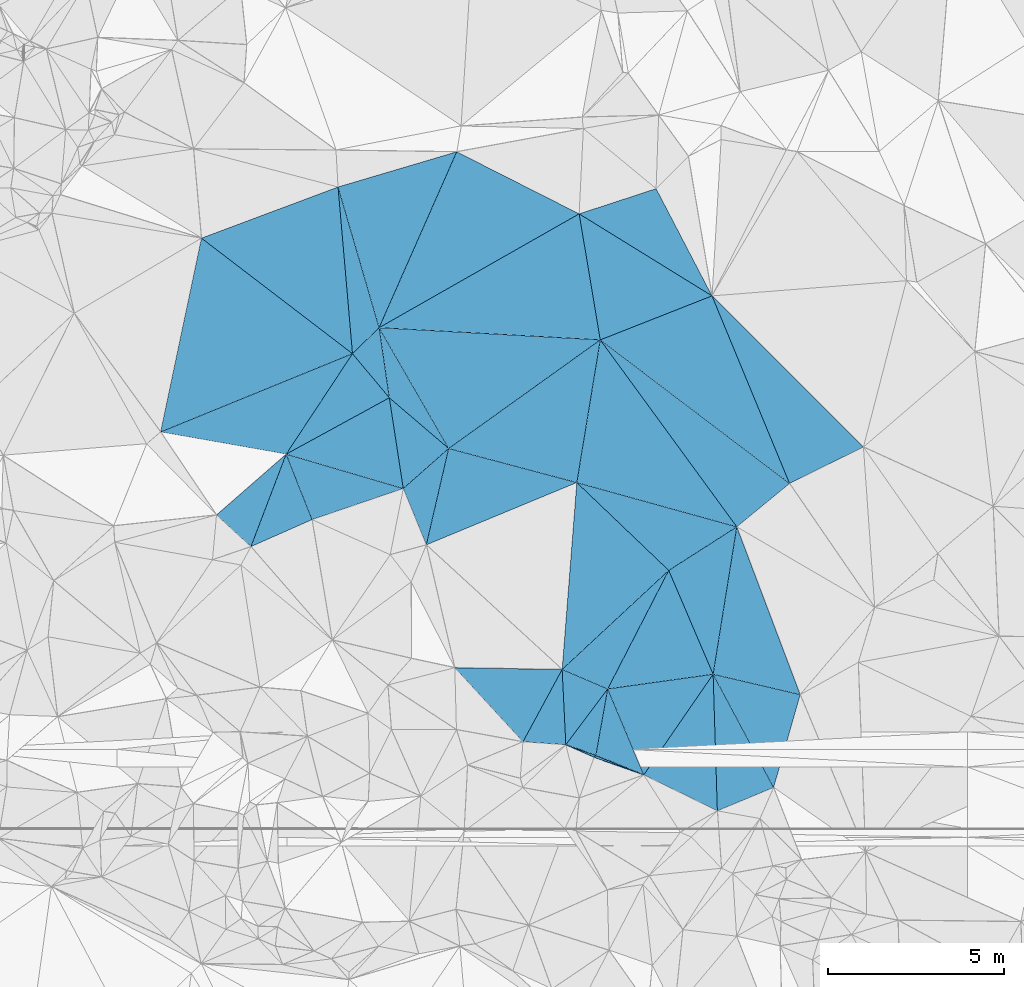
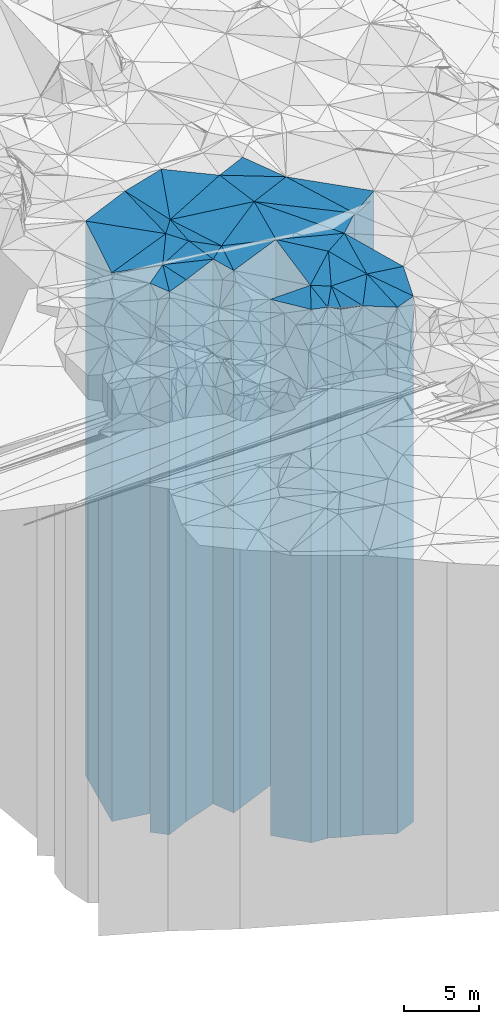
# One storey, part 218 of 275: 42 plates.
"""IFC2X3 building model written with IfcOpenShell, lengths in millimetres."""

from ifc_helpers import new_model, si_unit, frame, origin_with_axes, place, context, subcontext, project, spatial, faceted_brep, material, type_object, element, save


model = new_model("IFC2X3")

# Units and contexts
model_context = context("Model", 3, precision=1e-05, world=origin_with_axes())
body_context = subcontext(model_context, "Body", "Model", "MODEL_VIEW")
ifc_project = project(units=[si_unit("LENGTHUNIT", "METRE", prefix="MILLI"), si_unit("AREAUNIT", "SQUARE_METRE"), si_unit("VOLUMEUNIT", "CUBIC_METRE"), si_unit("MASSUNIT", "GRAM", prefix="KILO"), si_unit("TIMEUNIT", "SECOND"), si_unit("PLANEANGLEUNIT", "RADIAN"), si_unit("SOLIDANGLEUNIT", "STERADIAN"), si_unit("THERMODYNAMICTEMPERATUREUNIT", "DEGREE_CELSIUS"), si_unit("LUMINOUSINTENSITYUNIT", "LUMEN")], contexts=[model_context])

# Site, building, storey
site_placement = place(None, origin_with_axes())
site = spatial("IfcSite", under=ifc_project, at=site_placement, CompositionType="ELEMENT")
building_placement = place(site_placement, origin_with_axes())
building = spatial("IfcBuilding", under=site, at=building_placement, Name="Undefined", CompositionType="ELEMENT")
storey_placement = place(building_placement, origin_with_axes())
storey = spatial("IfcBuildingStorey", under=building, at=storey_placement, Name="Undefined", CompositionType="ELEMENT", Elevation=0.0)

# Plates
ifc_material = material()
plate_type_1 = type_object("IfcPlateType", PredefinedType="NOTDEFINED")
plate_1_placement = place(storey_placement, frame((-117335.519000868, 70928.3813490545, 29289.0), z_axis=(0.823524652008645, -0.567280484005963, 0.0), x_axis=(-0.567280484005959, -0.823524652008648, 0.0)))
element("IfcPlate", 1, at=plate_1_placement, inside=storey, type_object=plate_type_1, material=ifc_material, Name="00", context=body_context, shape_type="Brep", body=[
    faceted_brep([(-1.2732925824821e-11, -21871.0, 0.0), (3129.30419921872, -21461.0, 2301.9677734375), (3129.30419921872, 21461.0, 2301.9677734375), (-1.2732925824821e-11, 21461.0, 0.0), (3474.76611328123, -21701.0, 4.07453626394272e-09), (3474.76611328123, 21461.0, 4.07453626394272e-09)], [[[0, 1, 2, 3]], [[1, 4, 5, 2]], [[4, 0, 3, 5]], [[5, 3, 2]], [[4, 1, 0]]]),
])
plate_type_2 = type_object("IfcPlateType", PredefinedType="NOTDEFINED")
plate_2_placement = place(storey_placement, frame((-117214.984869905, 67045.4608601347, 29264.0), z_axis=(-0.383147422917195, 0.923687204800365, 0.0), x_axis=(0.923687204800366, 0.383147422917194, 0.0)))
element("IfcPlate", 2, at=plate_2_placement, inside=storey, type_object=plate_type_2, material=ifc_material, Name="00", context=body_context, shape_type="Brep", body=[
    faceted_brep([(-1.45519152283669e-11, -21486.0, 0.0), (1376.39514160156, -21896.0, 3632.78637695313), (1376.39514160156, 21436.0, 3632.78637695313), (-1.45519152283669e-11, 21436.0, 0.0), (1730.46240234374, -21436.0, 7.5960997492075e-09), (1730.46240234374, 21436.0, 7.5960997492075e-09)], [[[0, 1, 2, 3]], [[1, 4, 5, 2]], [[4, 0, 3, 5]], [[5, 3, 2]], [[4, 1, 0]]]),
])
plate_type_3 = type_object("IfcPlateType", PredefinedType="NOTDEFINED")
plate_3_placement = place(storey_placement, frame((-119306.686039508, 68066.8257396384, 29409.0), z_axis=(-0.823524652008645, 0.567280484005963, 0.0), x_axis=(0.567280484005957, 0.82352465200865, 0.0)))
element("IfcPlate", 3, at=plate_3_placement, inside=storey, type_object=plate_type_3, material=ifc_material, Name="00", context=body_context, shape_type="Brep", body=[
    faceted_brep([(5.45696821063757e-12, -21581.0, 0.0), (1430.59985351561, -22061.0, 2231.22924804688), (1430.59985351561, 21581.0, 2231.22924804688), (5.45696821063757e-12, 21581.0, 0.0), (3474.76611328126, -21751.0, 4.07453626394272e-09), (3474.76611328126, 21581.0, 4.07453626394272e-09)], [[[0, 1, 2, 3]], [[1, 4, 5, 2]], [[4, 0, 3, 5]], [[5, 3, 2]], [[4, 1, 0]]]),
])
plate_type_4 = type_object("IfcPlateType", PredefinedType="NOTDEFINED")
plate_4_placement = place(storey_placement, frame((-121522.572678423, 68923.9409031251, 29359.0), z_axis=(0.405411489970543, 0.914134302933581, 0.0), x_axis=(0.914134302933581, -0.405411489970543, 0.0)))
element("IfcPlate", 4, at=plate_4_placement, inside=storey, type_object=plate_type_4, material=ifc_material, Name="00", context=body_context, shape_type="Brep", body=[
    faceted_brep([(0.0, -21771.0, 1.45519152283669e-11), (902.671997070313, -21551.0, 71.995040893562), (902.671997070313, 21531.0, 71.995040893562), (0.0, 21531.0, 0.0), (877.838256835908, -21531.0, -9.53150447458029e-10), (877.838256835908, 21531.0, -9.53150447458029e-10)], [[[0, 1, 2, 3]], [[1, 4, 5, 2]], [[4, 0, 3, 5]], [[5, 3, 2]], [[4, 1, 0]]]),
])
plate_5_placement = place(storey_placement, frame((-119306.686039508, 68066.8257396384, 29359.0), z_axis=(-0.378622870041879, -0.925551037102358, 0.0), x_axis=(-0.925551037102361, 0.378622870041871, 0.0)))
element("IfcPlate", 5, at=plate_5_placement, inside=storey, type_object=plate_type_4, material=ifc_material, Name="00", context=body_context, shape_type="Brep", body=[
    faceted_brep([(-1.45519152283669e-11, -21631.0, 0.0), (1497.97351074222, -21531.0, 71.2414321899596), (1497.97351074222, 21531.0, 71.2414321899596), (0.0, 21531.0, 0.0), (1471.05407714847, -21551.0, -7.35235516913235e-09), (1471.05407714847, 21531.0, -7.35235516913235e-09)], [[[0, 1, 2, 3]], [[1, 4, 5, 2]], [[4, 0, 3, 5]], [[5, 3, 2]], [[4, 1, 0]]]),
])
plate_type_5 = type_object("IfcPlateType", PredefinedType="NOTDEFINED")
plate_6_placement = place(storey_placement, frame((-120332.606968009, 70510.692808131, 29369.0), z_axis=(0.984547475358155, -0.175117871063699, 0.0), x_axis=(-0.175117871063703, -0.984547475358155, 0.0)))
element("IfcPlate", 6, at=plate_6_placement, inside=storey, type_object=plate_type_5, material=ifc_material, Name="00", context=body_context, shape_type="Brep", body=[
    faceted_brep([(0.0, -22101.0, -1.45519152283669e-11), (2226.4460449219, -21621.0, 1438.03271484374), (2226.4460449219, 21541.0, 1438.03271484374), (0.0, 21541.0, -1.45519152283669e-11), (1916.50720214844, -21541.0, 9.73523128777742e-09), (1916.50720214844, 21541.0, 9.73523128777742e-09)], [[[0, 1, 2, 3]], [[1, 4, 5, 2]], [[4, 0, 3, 5]], [[5, 3, 2]], [[4, 1, 0]]]),
])
plate_type_6 = type_object("IfcPlateType", PredefinedType="NOTDEFINED")
plate_7_placement = place(storey_placement, frame((-118597.047680639, 73880.3714218895, 29649.0), z_axis=(0.68073982928558, -0.732525279307301, 0.0), x_axis=(-0.732525279307302, -0.680739829285579, 0.0)))
element("IfcPlate", 7, at=plate_7_placement, inside=storey, type_object=plate_type_6, material=ifc_material, Name="00", context=body_context, shape_type="Brep", body=[
    faceted_brep([(0.0, -22011.0, 2.91038304567337e-11), (3565.21557617187, -21821.0, 1286.91040039063), (3565.21557617187, 21821.0, 1286.91040039063), (0.0, 21821.0, 2.91038304567337e-11), (4136.49609375, -22001.0, 1.07975210994482e-08), (4136.49609375, 21821.0, 1.07975210994482e-08)], [[[0, 1, 2, 3]], [[1, 4, 5, 2]], [[4, 0, 3, 5]], [[5, 3, 2]], [[4, 1, 0]]]),
])
plate_type_7 = type_object("IfcPlateType", PredefinedType="NOTDEFINED")
plate_8_placement = place(storey_placement, frame((-126539.90181084, 78787.4549005297, 30069.0), z_axis=(-0.767759475959688, -0.640738157966345, 0.0), x_axis=(-0.640738157966349, 0.767759475959685, 0.0)))
element("IfcPlate", 8, at=plate_8_placement, inside=storey, type_object=plate_type_7, material=ifc_material, Name="00", context=body_context, shape_type="Brep", body=[
    faceted_brep([(-2.91038304567337e-11, -22241.0, 3.63797880709171e-11), (648.352050781221, -22301.0, 3278.25244140628), (648.352050781221, 22241.0, 3278.25244140628), (-2.91038304567337e-11, 22241.0, 3.63797880709171e-11), (1633.21765136716, -22441.0, 1.4239049050957e-08), (1633.21765136716, 22241.0, 1.4239049050957e-08)], [[[0, 1, 2, 3]], [[1, 4, 5, 2]], [[4, 0, 3, 5]], [[5, 3, 2]], [[4, 1, 0]]]),
])
plate_type_8 = type_object("IfcPlateType", PredefinedType="NOTDEFINED")
plate_9_placement = place(storey_placement, frame((-127586.366699978, 80041.3732534547, 30169.0), z_axis=(-0.607388450675607, -0.794404978575717, 0.0), x_axis=(-0.79440497857572, 0.607388450675603, 0.0)))
element("IfcPlate", 9, at=plate_9_placement, inside=storey, type_object=plate_type_8, material=ifc_material, Name="00", context=body_context, shape_type="Brep", body=[
    faceted_brep([(2.91038304567337e-11, -22341.0, 1.45519152283669e-11), (2981.69409179685, -22401.0, 5082.37158203126), (2981.69409179685, 22341.0, 5082.37158203126), (0.0, 22341.0, 0.0), (5406.25585937503, -22881.0, -1.52067514136434e-09), (5406.25585937503, 22341.0, -1.52067514136434e-09)], [[[0, 1, 2, 3]], [[1, 4, 5, 2]], [[4, 0, 3, 5]], [[5, 3, 2]], [[4, 1, 0]]]),
])
plate_type_9 = type_object("IfcPlateType", PredefinedType="NOTDEFINED")
plate_10_placement = place(storey_placement, frame((-125488.863877859, 74605.2641751521, 29924.0), z_axis=(-0.38255954606827, 0.92393083816487, 0.0), x_axis=(0.923930838164871, 0.382559546068267, 0.0)))
element("IfcPlate", 10, at=plate_10_placement, inside=storey, type_object=plate_type_9, material=ifc_material, Name="00", context=body_context, shape_type="Brep", body=[
    faceted_brep([(0.0, -22136.0, 0.0), (1636.08264160156, -22266.0, 2289.50512695314), (1636.08264160156, 22096.0, 2289.50512695314), (0.0, 22096.0, 0.0), (4631.306640625, -22096.0, -1.55705492943525e-08), (4631.306640625, 22096.0, -1.55705492943525e-08)], [[[0, 1, 2, 3]], [[1, 4, 5, 2]], [[4, 0, 3, 5]], [[5, 3, 2]], [[4, 1, 0]]]),
])
plate_type_10 = type_object("IfcPlateType", PredefinedType="NOTDEFINED")
plate_11_placement = place(storey_placement, frame((-126830.555289719, 80780.1215949911, 30009.0), z_axis=(0.989528991714559, 0.144334245958363, 0.0), x_axis=(0.144334245958364, -0.989528991714558, 0.0)))
element("IfcPlate", 11, at=plate_11_placement, inside=storey, type_object=plate_type_10, material=ifc_material, Name="00", context=body_context, shape_type="Brep", body=[
    faceted_brep([(0.0, -22931.0, -1.45519152283669e-11), (3683.07397460938, -22181.0, 1461.1525878906), (3683.07397460938, 22181.0, 1461.1525878906), (0.0, 22181.0, -1.45519152283669e-11), (2013.75268554688, -22301.0, 8.73114913702011e-11), (2013.75268554688, 22181.0, 8.73114913702011e-11)], [[[0, 1, 2, 3]], [[1, 4, 5, 2]], [[4, 0, 3, 5]], [[5, 3, 2]], [[4, 1, 0]]]),
])
plate_type_11 = type_object("IfcPlateType", PredefinedType="NOTDEFINED")
plate_12_placement = place(storey_placement, frame((-120543.166441148, 80433.0748159088, 29764.0), z_axis=(0.807613661011617, 0.58971194200848, 0.0), x_axis=(0.589711942008481, -0.807613661011616, 0.0)))
element("IfcPlate", 12, at=plate_12_placement, inside=storey, type_object=plate_type_11, material=ifc_material, Name="00", context=body_context, shape_type="Brep", body=[
    faceted_brep([(0.0, -22656.0, 0.0), (6470.38330078124, -22296.0, 1937.81896972655), (6470.38330078124, 21936.0, 1937.81896972655), (0.0, 21936.0, 0.0), (6580.64599609374, -21936.0, -2.33703758567572e-08), (6580.64599609374, 21936.0, -2.33703758567572e-08)], [[[0, 1, 2, 3]], [[1, 4, 5, 2]], [[4, 0, 3, 5]], [[5, 3, 2]], [[4, 1, 0]]]),
])
plate_type_12 = type_object("IfcPlateType", PredefinedType="NOTDEFINED")
plate_13_placement = place(storey_placement, frame((-124853.10875097, 77346.5075825559, 29924.0), z_axis=(0.257157203942215, 0.966369583782841, 0.0), x_axis=(0.966369583782842, -0.257157203942214, 0.0)))
element("IfcPlate", 13, at=plate_13_placement, inside=storey, type_object=plate_type_12, material=ifc_material, Name="00", context=body_context, shape_type="Brep", body=[
    faceted_brep([(0.0, -22266.0, 0.0), (3371.26416015625, -22496.0, 4091.09741210938), (3371.26416015625, 22096.0, 4091.09741210938), (0.0, 22096.0, 0.0), (3770.0397949219, -22096.0, -7.69796315580606e-09), (3770.0397949219, 22096.0, -7.69796315580606e-09)], [[[0, 1, 2, 3]], [[1, 4, 5, 2]], [[4, 0, 3, 5]], [[5, 3, 2]], [[4, 1, 0]]]),
])
plate_type_13 = type_object("IfcPlateType", PredefinedType="NOTDEFINED")
plate_14_placement = place(storey_placement, frame((-115162.495216853, 76350.259956521, 29944.0), z_axis=(-0.924123928763436, -0.382092873902186, 0.0), x_axis=(-0.382092873902188, 0.924123928763435, 0.0)))
element("IfcPlate", 14, at=plate_14_placement, inside=storey, type_object=plate_type_13, material=ifc_material, Name="00", context=body_context, shape_type="Brep", body=[
    faceted_brep([(1.45519152283669e-11, -22116.0, 1.45519152283669e-11), (5828.94287109374, -22476.0, 3412.39257812503), (5828.94287109374, 22116.0, 3412.39257812503), (1.45519152283669e-11, 22116.0, 1.45519152283669e-11), (5771.69824218751, -22626.0, 1.97906047105789e-08), (5771.69824218751, 22116.0, 1.97906047105789e-08)], [[[0, 1, 2, 3]], [[1, 4, 5, 2]], [[4, 0, 3, 5]], [[5, 3, 2]], [[4, 1, 0]]]),
])
plate_type_14 = type_object("IfcPlateType", PredefinedType="NOTDEFINED")
plate_15_placement = place(storey_placement, frame((-131881.123092767, 83325.0704877612, 30169.0), z_axis=(0.607388450675607, 0.794404978575717, 0.0), x_axis=(0.79440497857572, -0.607388450675604, 0.0)))
element("IfcPlate", 15, at=plate_15_placement, inside=storey, type_object=plate_type_14, material=ifc_material, Name="00", context=body_context, shape_type="Brep", body=[
    faceted_brep([(0.0, -22881.0, 0.0), (2201.44970703122, -23081.0, 3514.37329101563), (2201.44970703122, 22341.0, 3514.37329101563), (0.0, 22341.0, 0.0), (5406.255859375, -22341.0, 4.6253262553364e-08), (5406.25585937503, 22341.0, -1.52067514136434e-09)], [[[0, 1, 2, 3]], [[1, 4, 5, 2]], [[4, 0, 3, 5]], [[5, 3, 2]], [[4, 1, 0]]]),
])
plate_type_15 = type_object("IfcPlateType", PredefinedType="NOTDEFINED")
plate_16_placement = place(storey_placement, frame((-117367.819967116, 81684.0243631926, 30199.0), z_axis=(-0.886823622501307, -0.462108063740138, 0.0), x_axis=(-0.462108063740138, 0.886823622501307, 0.0)))
element("IfcPlate", 16, at=plate_16_placement, inside=storey, type_object=plate_type_15, material=ifc_material, Name="00", context=body_context, shape_type="Brep", body=[
    faceted_brep([(0.0, -22371.0, -1.45519152283669e-11), (3813.15576171875, -22411.0, 2270.58203125001), (3813.15576171875, 22371.0, 2270.58203125001), (0.0, 22371.0, 2.91038304567337e-11), (3437.04809570313, -22681.0, 2.58733052760363e-08), (3437.04809570313, 22371.0, 2.58733052760363e-08)], [[[0, 1, 2, 3]], [[1, 4, 5, 2]], [[4, 0, 3, 5]], [[5, 3, 2]], [[4, 1, 0]]]),
])
plate_type_16 = type_object("IfcPlateType", PredefinedType="NOTDEFINED")
plate_17_placement = place(storey_placement, frame((-127997.690766563, 84779.7709269565, 30384.0), z_axis=(0.959963147945012, 0.280126318983958, 0.0), x_axis=(0.280126318983954, -0.959963147945014, 0.0)))
element("IfcPlate", 17, at=plate_17_placement, inside=storey, type_object=plate_type_16, material=ifc_material, Name="00", context=body_context, shape_type="Brep", body=[
    faceted_brep([(-1.45519152283669e-11, -22866.0, -1.45519152283669e-11), (-14.640721321106, -22866.0, 3518.86132812497), (-14.640721321106, 22556.0, 3518.86132812497), (-1.45519152283669e-11, 22556.0, -1.45519152283669e-11), (4166.46142578124, -22556.0, -2.02562659978867e-08), (4166.46142578124, 22556.0, -2.02562659978867e-08)], [[[0, 1, 2, 3]], [[1, 4, 5, 2]], [[4, 0, 3, 5]], [[5, 3, 2]], [[4, 1, 0]]]),
])
plate_type_17 = type_object("IfcPlateType", PredefinedType="NOTDEFINED")
plate_18_placement = place(storey_placement, frame((-120543.166441148, 80433.0748159088, 30124.0), z_axis=(-0.366538590978086, 0.93040284894437, 0.0), x_axis=(0.930402848944371, 0.366538590978083, 0.0)))
element("IfcPlate", 18, at=plate_18_placement, inside=storey, type_object=plate_type_17, material=ifc_material, Name="00", context=body_context, shape_type="Brep", body=[
    faceted_brep([(0.0, -22296.0, 0.0), (754.847961425796, -22486.0, 3553.95629882813), (754.847961425796, 22296.0, 3553.95629882813), (0.0, 22296.0, 0.0), (3412.87280273438, -22446.0, -6.27187546342611e-09), (3412.87280273438, 22296.0, -6.27187546342611e-09)], [[[0, 1, 2, 3]], [[1, 4, 5, 2]], [[4, 0, 3, 5]], [[5, 3, 2]], [[4, 1, 0]]]),
])
plate_type_18 = type_object("IfcPlateType", PredefinedType="NOTDEFINED")
plate_19_placement = place(storey_placement, frame((-115162.495216853, 76350.259956521, 29944.0), z_axis=(-0.443076646098102, 0.896483734198483, 0.0), x_axis=(0.896483734198484, 0.443076646098102, 0.0)))
element("IfcPlate", 19, at=plate_19_placement, inside=storey, type_object=plate_type_18, material=ifc_material, Name="00", context=body_context, shape_type="Brep", body=[
    faceted_brep([(1.45519152283669e-11, -22116.0, 1.45519152283669e-11), (386.228668212905, -22626.0, 5758.7607421875), (386.228668212905, 22116.0, 5758.7607421875), (1.45519152283669e-11, 22116.0, 1.45519152283669e-11), (2342.1357421875, -22576.0, -5.1368260756135e-09), (2342.1357421875, 22116.0, -5.1368260756135e-09)], [[[0, 1, 2, 3]], [[1, 4, 5, 2]], [[4, 0, 3, 5]], [[5, 3, 2]], [[4, 1, 0]]]),
])
plate_type_19 = type_object("IfcPlateType", PredefinedType="NOTDEFINED")
plate_20_placement = place(storey_placement, frame((-129472.235140863, 77184.7318297416, 30099.0), z_axis=(-0.834544247110576, 0.550940922072995, 0.0), x_axis=(0.550940922072999, 0.834544247110574, 0.0)))
element("IfcPlate", 20, at=plate_20_placement, inside=storey, type_object=plate_type_19, material=ifc_material, Name="00", context=body_context, shape_type="Brep", body=[
    faceted_brep([(0.0, -22271.0, 1.45519152283669e-11), (-1440.78466796872, -22471.0, 3326.3552246094), (-1440.78466796872, 22271.0, 3326.3552246094), (-2.91038304567337e-11, 22271.0, -1.45519152283669e-11), (3422.99584960939, -22411.0, -2.61934474110603e-10), (3422.99584960939, 22271.0, -2.61934474110603e-10)], [[[0, 1, 2, 3]], [[1, 4, 5, 2]], [[4, 0, 3, 5]], [[5, 3, 2]], [[4, 1, 0]]]),
])
plate_type_20 = type_object("IfcPlateType", PredefinedType="NOTDEFINED")
plate_21_placement = place(storey_placement, frame((-120543.166441148, 80433.0748159088, 29764.0), z_axis=(0.986759118977135, -0.162192604996246, 0.0), x_axis=(-0.162192604996242, -0.986759118977136, 0.0)))
element("IfcPlate", 21, at=plate_21_placement, inside=storey, type_object=plate_type_20, material=ifc_material, Name="00", context=body_context, shape_type="Brep", body=[
    faceted_brep([(0.0, -22656.0, 0.0), (4614.83056640624, -21936.0, 4691.29394531253), (4614.83056640624, 21936.0, 4691.29394531253), (0.0, 21936.0, 0.0), (4110.48681640625, -22256.0, 9.37143340706825e-09), (4110.48681640625, 21936.0, 9.37143340706825e-09)], [[[0, 1, 2, 3]], [[1, 4, 5, 2]], [[4, 0, 3, 5]], [[5, 3, 2]], [[4, 1, 0]]]),
])
plate_type_21 = type_object("IfcPlateType", PredefinedType="NOTDEFINED")
plate_22_placement = place(storey_placement, frame((-127997.690766563, 84779.7709269565, 30169.0), z_axis=(0.996253469808289, 0.0864813499833604, 0.0), x_axis=(0.0864813499833582, -0.996253469808289, 0.0)))
element("IfcPlate", 22, at=plate_22_placement, inside=storey, type_object=plate_type_21, material=ifc_material, Name="00", context=body_context, shape_type="Brep", body=[
    faceted_brep([(0.0, -23081.0, 0.0), (4085.60009765624, -22771.0, 816.867675781235), (4085.60009765624, 22341.0, 816.867675781235), (0.0, 22341.0, 0.0), (4756.21679687499, -22341.0, -3.5579432733357e-08), (4756.21679687499, 22341.0, -3.5579432733357e-08)], [[[0, 1, 2, 3]], [[1, 4, 5, 2]], [[4, 0, 3, 5]], [[5, 3, 2]], [[4, 1, 0]]]),
])
plate_type_22 = type_object("IfcPlateType", PredefinedType="NOTDEFINED")
plate_23_placement = place(storey_placement, frame((-121143.515837382, 84016.3666826762, 30219.0), z_axis=(-0.451930741925739, -0.892053027853418, 0.0), x_axis=(-0.892053027853419, 0.451930741925738, 0.0)))
element("IfcPlate", 23, at=plate_23_placement, inside=storey, type_object=plate_type_22, material=ifc_material, Name="00", context=body_context, shape_type="Brep", body=[
    faceted_brep([(0.0, -22391.0, -1.45519152283669e-11), (3610.58203125, -22721.0, 5457.05029296875), (3610.58203125, 22391.0, 5457.05029296875), (0.0, 22391.0, -1.45519152283669e-11), (3901.44848632815, -23031.0, -2.69938027486205e-08), (3901.44848632815, 22391.0, -2.69938027486205e-08)], [[[0, 1, 2, 3]], [[1, 4, 5, 2]], [[4, 0, 3, 5]], [[5, 3, 2]], [[4, 1, 0]]]),
])
plate_type_23 = type_object("IfcPlateType", PredefinedType="NOTDEFINED")
plate_24_placement = place(storey_placement, frame((-121209.85697089, 76377.0146909164, 29744.0), z_axis=(0.690851817525725, 0.722996380503667, 0.0), x_axis=(0.722996380503661, -0.690851817525731, 0.0)))
element("IfcPlate", 24, at=plate_24_placement, inside=storey, type_object=plate_type_23, material=ifc_material, Name="00", context=body_context, shape_type="Brep", body=[
    faceted_brep([(1.09139364212751e-11, -22276.0, 0.0), (4157.21435546878, -21956.0, 2231.62915039064), (4157.21435546878, 21916.0, 2231.62915039064), (0.0, 21916.0, 1.45519152283669e-11), (3613.86230468747, -21916.0, -1.76260073203593e-08), (3613.86230468747, 21916.0, -1.76260073203593e-08)], [[[0, 1, 2, 3]], [[1, 4, 5, 2]], [[4, 0, 3, 5]], [[5, 3, 2]], [[4, 1, 0]]]),
])
plate_type_24 = type_object("IfcPlateType", PredefinedType="NOTDEFINED")
plate_25_placement = place(storey_placement, frame((-126142.740235707, 76207.7140834634, 30039.0), z_axis=(-0.988355663766495, -0.152161367964052, 0.0), x_axis=(-0.15216136796405, 0.988355663766495, 0.0)))
element("IfcPlate", 25, at=plate_25_placement, inside=storey, type_object=plate_type_24, material=ifc_material, Name="00", context=body_context, shape_type="Brep", body=[
    faceted_brep([(0.0, -22211.0, 0.0), (1472.26147460936, -22331.0, 3142.06079101563), (1472.26147460936, 22211.0, 3142.06079101563), (-1.45519152283669e-11, 22211.0, -1.45519152283669e-11), (2610.1340332031, -22271.0, -7.74161890149117e-09), (2610.1340332031, 22211.0, -7.74161890149117e-09)], [[[0, 1, 2, 3]], [[1, 4, 5, 2]], [[4, 0, 3, 5]], [[5, 3, 2]], [[4, 1, 0]]]),
])
plate_type_25 = type_object("IfcPlateType", PredefinedType="NOTDEFINED")
plate_26_placement = place(storey_placement, frame((-126830.555289719, 80780.1215949911, 30069.0), z_axis=(0.698988341983337, -0.715133062982957, 0.0), x_axis=(-0.715133062982949, -0.698988341983345, 0.0)))
element("IfcPlate", 26, at=plate_26_placement, inside=storey, type_object=plate_type_25, material=ifc_material, Name="00", context=body_context, shape_type="Brep", body=[
    faceted_brep([(3.63797880709171e-12, -22871.0, 2.91038304567337e-11), (1184.99487304686, -22241.0, 1628.18518066403), (1184.99487304686, 22241.0, 1628.18518066403), (-2.91038304567337e-11, 22241.0, 3.63797880709171e-11), (1056.88220214843, -22441.0, -3.66708263754845e-09), (1056.88220214843, 22241.0, -3.66708263754845e-09)], [[[0, 1, 2, 3]], [[1, 4, 5, 2]], [[4, 0, 3, 5]], [[5, 3, 2]], [[4, 1, 0]]]),
])
plate_type_26 = type_object("IfcPlateType", PredefinedType="NOTDEFINED")
plate_27_placement = place(storey_placement, frame((-121627.135643603, 71064.4937724354, 29739.0), z_axis=(-0.68073982928558, 0.732525279307301, 0.0), x_axis=(0.732525279307302, 0.680739829285579, 0.0)))
element("IfcPlate", 27, at=plate_27_placement, inside=storey, type_object=plate_type_26, material=ifc_material, Name="00", context=body_context, shape_type="Brep", body=[
    faceted_brep([(-1.63709046319127e-11, -21911.0, 0.0), (3922.11181640624, -22281.0, 3607.49755859375), (3922.11181640624, 21911.0, 3607.49755859375), (0.0, 21911.0, -2.91038304567337e-11), (4136.49609374999, -21921.0, 1.07684172689915e-08), (4136.49609374999, 21911.0, 1.07684172689915e-08)], [[[0, 1, 2, 3]], [[1, 4, 5, 2]], [[4, 0, 3, 5]], [[5, 3, 2]], [[4, 1, 0]]]),
])
plate_type_27 = type_object("IfcPlateType", PredefinedType="NOTDEFINED")
plate_28_placement = place(storey_placement, frame((-120543.166441148, 80433.0748159088, 30124.0), z_axis=(-0.986253683219876, -0.165238229036833, 0.0), x_axis=(-0.165238229036837, 0.986253683219875, 0.0)))
element("IfcPlate", 28, at=plate_28_placement, inside=storey, type_object=plate_type_27, material=ifc_material, Name="00", context=body_context, shape_type="Brep", body=[
    faceted_brep([(0.0, -22296.0, 0.0), (1381.19311523436, -22816.0, 6143.615234375), (1381.19311523436, 22296.0, 6143.615234375), (0.0, 22296.0, 0.0), (3633.2353515625, -22486.0, 1.57160684466362e-09), (3633.2353515625, 22296.0, 1.57160684466362e-09)], [[[0, 1, 2, 3]], [[1, 4, 5, 2]], [[4, 0, 3, 5]], [[5, 3, 2]], [[4, 1, 0]]]),
])
plate_type_28 = type_object("IfcPlateType", PredefinedType="NOTDEFINED")
plate_29_placement = place(storey_placement, frame((-117335.519000868, 70928.3813490545, 29494.0), z_axis=(0.227532367027468, 0.973770518117527, 0.0), x_axis=(0.973770518117529, -0.22753236702746, 0.0)))
element("IfcPlate", 29, at=plate_29_placement, inside=storey, type_object=plate_type_28, material=ifc_material, Name="00", context=body_context, shape_type="Brep", body=[
    faceted_brep([(0.0, -21666.0, 0.0), (-297.992889404341, -22206.0, 4233.30859374999), (-297.992889404341, 21666.0, 4233.30859374999), (0.0, 21666.0, 0.0), (2542.00708007813, -21766.0, 1.43627403303981e-08), (2542.00708007813, 21666.0, 1.43627403303981e-08)], [[[0, 1, 2, 3]], [[1, 4, 5, 2]], [[4, 0, 3, 5]], [[5, 3, 2]], [[4, 1, 0]]]),
])
plate_type_29 = type_object("IfcPlateType", PredefinedType="NOTDEFINED")
plate_30_placement = place(storey_placement, frame((-120332.606968009, 70510.692808131, 29494.0), z_axis=(-0.13803078402185, 0.990427939156764, 0.0), x_axis=(0.990427939156764, 0.138030784021847, 0.0)))
element("IfcPlate", 30, at=plate_30_placement, inside=storey, type_object=plate_type_29, material=ifc_material, Name="00", context=body_context, shape_type="Brep", body=[
    faceted_brep([(7.27595761418343e-12, -21976.0, -2.91038304567337e-11), (2184.06567382814, -22166.0, 3097.86328125), (2184.06567382814, 21666.0, 3097.86328125), (0.0, 21666.0, 0.0), (3026.05346679686, -21666.0, -3.91446519643068e-09), (3026.05346679686, 21666.0, -3.91446519643068e-09)], [[[0, 1, 2, 3]], [[1, 4, 5, 2]], [[4, 0, 3, 5]], [[5, 3, 2]], [[4, 1, 0]]]),
])
plate_type_30 = type_object("IfcPlateType", PredefinedType="NOTDEFINED")
plate_31_placement = place(storey_placement, frame((-130474.318658095, 74554.8594707682, 29919.0), z_axis=(-0.404396271985505, 0.914583869967225, 0.0), x_axis=(0.914583869967225, 0.404396271985505, 0.0)))
element("IfcPlate", 31, at=plate_31_placement, inside=storey, type_object=plate_type_30, material=ifc_material, Name="00", context=body_context, shape_type="Brep", body=[
    faceted_brep([(0.0, -22191.0, 0.0), (1980.0, -22451.0, 2000.00000000001), (1980.0, 22091.0, 2000.00000000001), (2.91038304567337e-11, 22091.0, -2.91038304567337e-11), (1900.0, -22091.0, -1.11031113192439e-08), (1900.0, 22091.0, -1.11031113192439e-08)], [[[0, 1, 2, 3]], [[1, 4, 5, 2]], [[4, 0, 3, 5]], [[5, 3, 2]], [[4, 1, 0]]]),
])
plate_type_31 = type_object("IfcPlateType", PredefinedType="NOTDEFINED")
plate_32_placement = place(storey_placement, frame((-129472.235140863, 77184.7318297416, 29919.0), z_axis=(0.930016005177667, 0.367519020070218, 0.0), x_axis=(0.367519020070211, -0.93001600517767, 0.0)))
element("IfcPlate", 32, at=plate_32_placement, inside=storey, type_object=plate_type_31, material=ifc_material, Name="00", context=body_context, shape_type="Brep", body=[
    faceted_brep([(-2.91038304567337e-11, -22451.0, -2.18278728425503e-11), (2132.29492187503, -22331.0, 2737.41088867188), (2132.29492187503, 22091.0, 2737.41088867188), (2.91038304567337e-11, 22091.0, -2.91038304567337e-11), (2001.59936523438, -22091.0, -6.03904481977224e-09), (2001.59936523438, 22091.0, -6.03904481977224e-09)], [[[0, 1, 2, 3]], [[1, 4, 5, 2]], [[4, 0, 3, 5]], [[5, 3, 2]], [[4, 1, 0]]]),
])
plate_type_32 = type_object("IfcPlateType", PredefinedType="NOTDEFINED")
plate_33_placement = place(storey_placement, frame((-124853.10875097, 77346.5075825559, 29944.0), z_axis=(0.661910276065905, -0.749583075074643, 0.0), x_axis=(-0.749583075074636, -0.661910276065912, 0.0)))
element("IfcPlate", 33, at=plate_33_placement, inside=storey, type_object=plate_type_32, material=ifc_material, Name="00", context=body_context, shape_type="Brep", body=[
    faceted_brep([(-7.27595761418343e-12, -22246.0, 0.0), (2291.00854492188, -22116.0, 1633.97680664063), (2291.00854492188, 22116.0, 1633.97680664063), (1.45519152283669e-11, 22116.0, 1.45519152283669e-11), (1720.46508789065, -22306.0, -9.92440618574619e-09), (1720.46508789065, 22116.0, -9.92440618574619e-09)], [[[0, 1, 2, 3]], [[1, 4, 5, 2]], [[4, 0, 3, 5]], [[5, 3, 2]], [[4, 1, 0]]]),
])
plate_type_33 = type_object("IfcPlateType", PredefinedType="NOTDEFINED")
plate_34_placement = place(storey_placement, frame((-122740.829133062, 69008.5057346448, 29479.0), z_axis=(0.0692480069657605, 0.997599475506714, 0.0), x_axis=(0.997599475506713, -0.0692480069657623, 0.0)))
element("IfcPlate", 34, at=plate_34_placement, inside=storey, type_object=plate_type_33, material=ifc_material, Name="00", context=body_context, shape_type="Brep", body=[
    faceted_brep([(0.0, -21841.0, 0.0), (968.64697265625, -22171.0, 2128.17358398439), (968.64697265625, 21651.0, 2128.17358398439), (-2.91038304567337e-11, 21651.0, 7.27595761418343e-12), (1221.18798828126, -21651.0, -6.40284270048141e-10), (1221.18798828126, 21651.0, -6.40284270048141e-10)], [[[0, 1, 2, 3]], [[1, 4, 5, 2]], [[4, 0, 3, 5]], [[5, 3, 2]], [[4, 1, 0]]]),
])
plate_type_34 = type_object("IfcPlateType", PredefinedType="NOTDEFINED")
plate_35_placement = place(storey_placement, frame((-120332.606968009, 70510.692808131, 29479.0), z_axis=(-0.393320977038912, -0.919401223090961, 0.0), x_axis=(-0.91940122309096, 0.393320977038915, 0.0)))
element("IfcPlate", 35, at=plate_35_placement, inside=storey, type_object=plate_type_34, material=ifc_material, Name="00", context=body_context, shape_type="Brep", body=[
    faceted_brep([(-1.45519152283669e-11, -21991.0, 0.0), (469.953125, -21651.0, 1926.90014648438), (469.953125, 21651.0, 1926.90014648438), (-2.91038304567337e-11, 21651.0, 7.27595761418343e-12), (1408.01281738281, -22171.0, -5.18775777891278e-09), (1408.01281738281, 21651.0, -5.18775777891278e-09)], [[[0, 1, 2, 3]], [[1, 4, 5, 2]], [[4, 0, 3, 5]], [[5, 3, 2]], [[4, 1, 0]]]),
])
plate_type_35 = type_object("IfcPlateType", PredefinedType="NOTDEFINED")
plate_36_placement = place(storey_placement, frame((-120668.221635461, 68623.8004436886, 29369.0), z_axis=(-0.984547475358155, 0.175117871063699, 0.0), x_axis=(0.175117871063703, 0.984547475358155, 0.0)))
element("IfcPlate", 36, at=plate_36_placement, inside=storey, type_object=plate_type_35, material=ifc_material, Name="00", context=body_context, shape_type="Brep", body=[
    faceted_brep([(1.45519152283669e-11, -21541.0, 0.0), (145.890396118164, -21761.0, 893.709106445313), (145.890396118164, 21541.0, 893.709106445313), (0.0, 21541.0, -1.45519152283669e-11), (1916.50720214844, -22101.0, 9.72067937254906e-09), (1916.50720214844, 21541.0, 9.73523128777742e-09)], [[[0, 1, 2, 3]], [[1, 4, 5, 2]], [[4, 0, 3, 5]], [[5, 3, 2]], [[4, 1, 0]]]),
])
plate_type_36 = type_object("IfcPlateType", PredefinedType="NOTDEFINED")
plate_37_placement = place(storey_placement, frame((-115616.578924319, 67708.4830566807, 29264.0), z_axis=(-0.961362802184405, 0.275284512052801, 0.0), x_axis=(0.275284512052802, 0.961362802184405, 0.0)))
element("IfcPlate", 37, at=plate_37_placement, inside=storey, type_object=plate_type_36, material=ifc_material, Name="00", context=body_context, shape_type="Brep", body=[
    faceted_brep([(0.0, -21436.0, 1.45519152283669e-11), (2622.29296875, -21896.0, 2538.91308593753), (2622.29296875, 21436.0, 2538.91308593753), (-1.45519152283669e-11, 21436.0, 0.0), (2747.67163085938, -21996.0, -2.01980583369732e-08), (2747.67163085938, 21436.0, -2.01980583369732e-08)], [[[0, 1, 2, 3]], [[1, 4, 5, 2]], [[4, 0, 3, 5]], [[5, 3, 2]], [[4, 1, 0]]]),
])
plate_type_37 = type_object("IfcPlateType", PredefinedType="NOTDEFINED")
plate_38_placement = place(storey_placement, frame((-122740.829133062, 69008.5057346448, 29574.0), z_axis=(-0.879286001928225, 0.476294159961129, 0.0), x_axis=(0.476294159961122, 0.879286001928229, 0.0)))
element("IfcPlate", 38, at=plate_38_placement, inside=storey, type_object=plate_type_37, material=ifc_material, Name="00", context=body_context, shape_type="Brep", body=[
    faceted_brep([(6.82121026329696e-12, -21746.0, 2.91038304567337e-11), (929.456909179665, -21976.0, 2706.77099609378), (929.456909179665, 21746.0, 2706.77099609378), (-1.45519152283669e-11, 21746.0, -1.45519152283669e-11), (2338.24731445313, -22076.0, 8.81846062839031e-09), (2338.24731445313, 21746.0, 8.81846062839031e-09)], [[[0, 1, 2, 3]], [[1, 4, 5, 2]], [[4, 0, 3, 5]], [[5, 3, 2]], [[4, 1, 0]]]),
])
plate_type_38 = type_object("IfcPlateType", PredefinedType="NOTDEFINED")
plate_39_placement = place(storey_placement, frame((-116662.480991635, 75118.4553147653, 29494.0), z_axis=(0.539041716005617, -0.842279068008769, 0.0), x_axis=(-0.842279068008772, -0.539041716005613, 0.0)))
element("IfcPlate", 39, at=plate_39_placement, inside=storey, type_object=plate_type_38, material=ifc_material, Name="00", context=body_context, shape_type="Brep", body=[
    faceted_brep([(0.0, -22206.0, 0.0), (2825.5104980469, -21666.0, 3166.41601562499), (2825.5104980469, 21666.0, 3166.41601562499), (0.0, 21666.0, 0.0), (2296.82397460938, -22166.0, -8.84756445884705e-09), (2296.82397460938, 21666.0, -8.84756445884705e-09)], [[[0, 1, 2, 3]], [[1, 4, 5, 2]], [[4, 0, 3, 5]], [[5, 3, 2]], [[4, 1, 0]]]),
])
plate_type_39 = type_object("IfcPlateType", PredefinedType="NOTDEFINED")
plate_40_placement = place(storey_placement, frame((-129472.235140863, 77184.7318297416, 29969.0), z_axis=(0.657589552768557, -0.753376386734844, 0.0), x_axis=(-0.753376386734845, -0.657589552768555, 0.0)))
element("IfcPlate", 40, at=plate_40_placement, inside=storey, type_object=plate_type_39, material=ifc_material, Name="00", context=body_context, shape_type="Brep", body=[
    faceted_brep([(1.45519152283669e-11, -22401.0, 0.0), (2484.32275390626, -22141.0, 1322.32409667969), (2484.32275390626, 22141.0, 1322.32409667969), (-2.18278728425503e-11, 22141.0, 0.0), (2628.40258789065, -22631.0, -6.34463503956795e-09), (2628.40258789065, 22141.0, -6.34463503956795e-09)], [[[0, 1, 2, 3]], [[1, 4, 5, 2]], [[4, 0, 3, 5]], [[5, 3, 2]], [[4, 1, 0]]]),
])
plate_type_40 = type_object("IfcPlateType", PredefinedType="NOTDEFINED")
plate_41_placement = place(storey_placement, frame((-124853.10875097, 77346.5075825559, 30009.0), z_axis=(-0.582241642119332, 0.813015787166635, 0.0), x_axis=(0.813015787166634, 0.582241642119334, 0.0)))
element("IfcPlate", 41, at=plate_41_placement, inside=storey, type_object=plate_type_40, material=ifc_material, Name="00", context=body_context, shape_type="Brep", body=[
    faceted_brep([(0.0, -22181.0, 0.0), (391.497802734368, -22931.0, 3942.93408203125), (391.497802734368, 22181.0, 3942.93408203125), (0.0, 22181.0, -1.45519152283669e-11), (5301.17919921874, -22411.0, 2.83180270344019e-08), (5301.17919921874, 22181.0, 2.83180270344019e-08)], [[[0, 1, 2, 3]], [[1, 4, 5, 2]], [[4, 0, 3, 5]], [[5, 3, 2]], [[4, 1, 0]]]),
])
plate_type_41 = type_object("IfcPlateType", PredefinedType="NOTDEFINED")
plate_42_placement = place(storey_placement, frame((-124853.10875097, 77346.5075825559, 30009.0), z_axis=(-0.649523616107837, -0.760341418126225, 0.0), x_axis=(-0.760341418126231, 0.64952361610783, 0.0)))
element("IfcPlate", 42, at=plate_42_placement, inside=storey, type_object=plate_type_41, material=ifc_material, Name="00", context=body_context, shape_type="Brep", body=[
    faceted_brep([(0.0, -22181.0, 0.0), (240.886962890625, -22241.0, 1703.51794433594), (240.886962890625, 22181.0, 1703.51794433594), (0.0, 22181.0, -1.45519152283669e-11), (2218.46801757813, -22301.0, 9.29139787331223e-09), (2218.46801757813, 22181.0, 9.29139787331223e-09)], [[[0, 1, 2, 3]], [[1, 4, 5, 2]], [[4, 0, 3, 5]], [[5, 3, 2]], [[4, 1, 0]]]),
])

save(model, "model.ifc")
